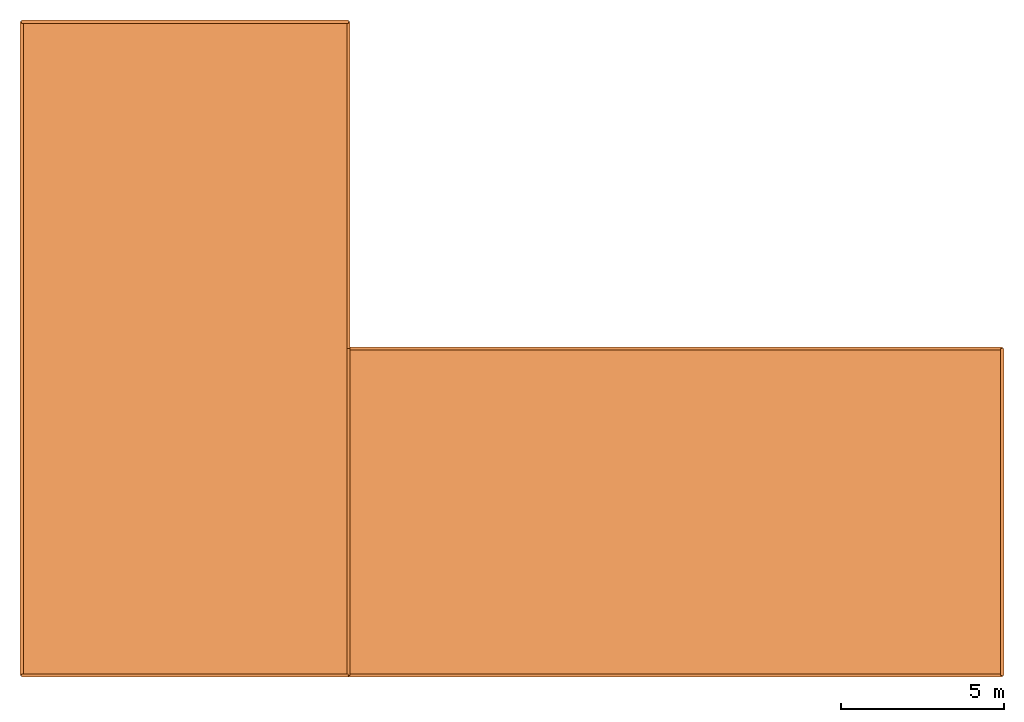
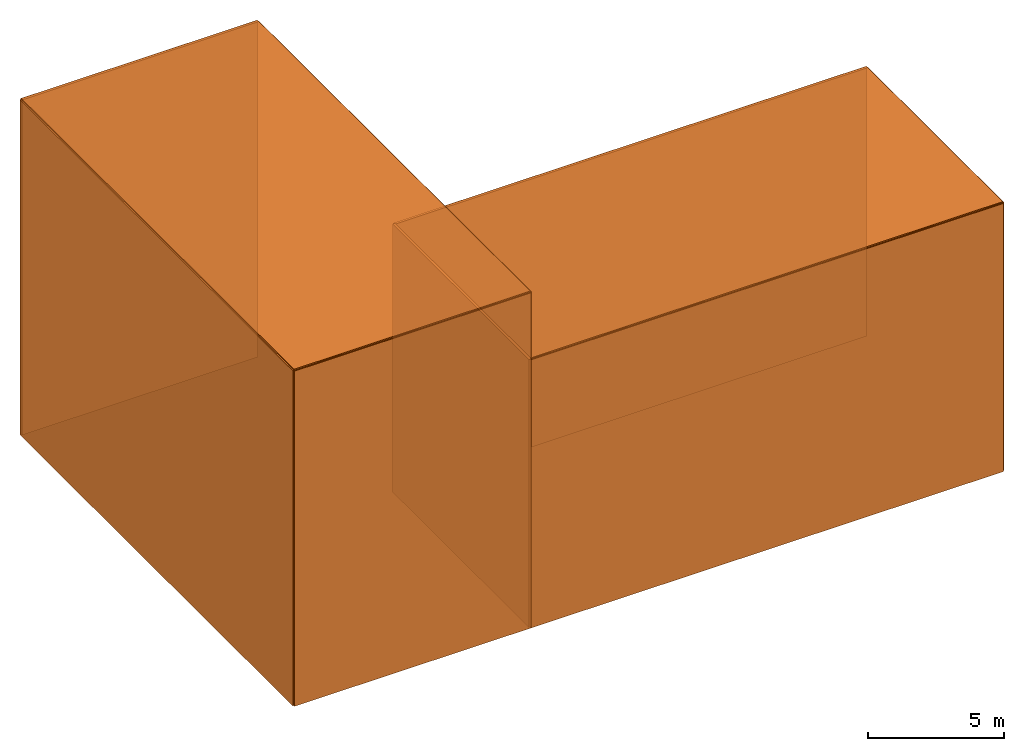
# Not in any storey: 11 proxies.
"""IFC4 building model written with IfcOpenShell, lengths in metres."""

import ifcopenshell
import ifcopenshell.guid

model = None  # the IFC model being written
_history = None  # IfcOwnerHistory: only IFC2X3 demands one
_inside = {}  # id of a spatial element -> (the spatial element, [elements in it])
_under = {}  # id of a project, library or spatial element -> (it, [spatial elements below it])
_declared = {}  # id of a project -> (the project, [libraries it declares])
_typed = {}  # id of a type object -> (the type object, [elements of that type])
_made_of = {}  # id of a material, layer set ... -> (it, [elements and type objects made of it])


def new_model(schema):
    """Start an empty IFC model of exactly this schema.

    Asked for "IFC4X3", IfcOpenShell would pick the latest addendum, in which some entities
    have other attributes; the version numbers below select the first issue.
    IFC2X3 requires an IfcOwnerHistory on every rooted entity: one is made here for all.
    """
    global model, _history
    if schema == "IFC4X3":
        model = ifcopenshell.file(schema_version=(4, 3, 0, 0))
    else:
        model = ifcopenshell.file(schema=schema)
    _inside.clear()
    _under.clear()
    _declared.clear()
    _typed.clear()
    _made_of.clear()
    _history = None
    if model.schema == "IFC2X3":
        org = make("IfcOrganization", Name="unknown")
        user = make(
            "IfcPersonAndOrganization",
            ThePerson=make("IfcPerson", FamilyName="unknown"),
            TheOrganization=org,
        )
        app = make(
            "IfcApplication",
            ApplicationDeveloper=org,
            Version="unknown",
            ApplicationFullName="unknown",
            ApplicationIdentifier="unknown",
        )
        _history = make(
            "IfcOwnerHistory",
            OwningUser=user,
            OwningApplication=app,
            ChangeAction="ADDED",
            CreationDate=0,
        )
    return model


def make(cls, **values):
    """One entity of the class cls with the attributes given. An attribute that is None is left unset."""
    return model.create_entity(
        cls, **{name: value for name, value in values.items() if value is not None}
    )


def rooted(cls, **values):
    """An entity with a GlobalId (a new one), such as an element, a storey or a relation."""
    return make(cls, GlobalId=ifcopenshell.guid.new(), OwnerHistory=_history, **values)


def si_unit(unit_type, name, prefix=None):
    """IfcSIUnit, for example si_unit("LENGTHUNIT", "METRE", prefix="MILLI")."""
    return make("IfcSIUnit", UnitType=unit_type, Prefix=prefix, Name=name)


def derived_unit(unit_type, elements):
    """IfcDerivedUnit: a product of units, each with its exponent."""
    return make(
        "IfcDerivedUnit",
        Elements=[
            make("IfcDerivedUnitElement", Unit=unit, Exponent=power)
            for unit, power in elements
        ],
        UnitType=unit_type,
    )


def assignment(units):
    """IfcUnitAssignment: the units of a project."""
    return None if units is None else make("IfcUnitAssignment", Units=units)


def point(xyz):
    """IfcCartesianPoint."""
    return None if xyz is None else make("IfcCartesianPoint", Coordinates=xyz)


def direction(xyz):
    """IfcDirection."""
    return None if xyz is None else make("IfcDirection", DirectionRatios=xyz)


def frame(location, z_axis=None, x_axis=None):
    """IfcAxis2Placement3D, a coordinate frame: its origin and axes. An axis left out is left unset."""
    return make(
        "IfcAxis2Placement3D",
        Location=point(location),
        Axis=direction(z_axis),
        RefDirection=direction(x_axis),
    )


def origin_with_axes():
    """The frame at (0, 0, 0) with the z axis (0, 0, 1) and the x axis (1, 0, 0) written out."""
    return frame((0.0, 0.0, 0.0), z_axis=(0.0, 0.0, 1.0), x_axis=(1.0, 0.0, 0.0))


def place(relative_to, where):
    """IfcLocalPlacement: puts the frame where relative to a parent placement (None: the world)."""
    return make(
        "IfcLocalPlacement", PlacementRelTo=relative_to, RelativePlacement=where
    )


def context(
    kind, dimensions, precision=None, world=None, true_north=None, identifier=None
):
    """IfcGeometricRepresentationContext, for example the 3D "Model" context."""
    return make(
        "IfcGeometricRepresentationContext",
        ContextIdentifier=identifier,
        ContextType=kind,
        CoordinateSpaceDimension=dimensions,
        Precision=precision,
        WorldCoordinateSystem=world,
        TrueNorth=true_north,
    )


def subcontext(parent, identifier, kind, view, scale=None):
    """IfcGeometricRepresentationSubContext, for example "Body" below "Model"."""
    return make(
        "IfcGeometricRepresentationSubContext",
        ContextIdentifier=identifier,
        ContextType=kind,
        ParentContext=parent,
        TargetScale=scale,
        TargetView=view,
    )


def project(units=None, contexts=None):
    """IfcProject with its units and contexts."""
    return rooted(
        "IfcProject",
        Name="project",
        RepresentationContexts=contexts,
        UnitsInContext=assignment(units),
    )


def spatial(cls, under=None, at=None, **own):
    """A site, building, storey or space (cls), placed at a placement, below another one or the project."""
    s = rooted(cls, ObjectPlacement=at, **own)
    if under is not None:
        _under.setdefault(under.id(), (under, []))[1].append(s)
    return s


def faces_of(points, faces, orient=None, outer=None):
    """IfcFace entities. A face is a list of loops; a loop is a list of indices into points, from 0.

    orient and outer hold one flag for each loop. By default every Orientation is true, the
    first loop of a face is its IfcFaceOuterBound and the others are IfcFaceBound.
    """
    made = []
    for i, loops in enumerate(faces):
        bounds = []
        for j, loop in enumerate(loops):
            is_outer = j == 0 if outer is None else outer[i][j]
            bounds.append(
                make(
                    "IfcFaceOuterBound" if is_outer else "IfcFaceBound",
                    Bound=make("IfcPolyLoop", Polygon=[points[k] for k in loop]),
                    Orientation=True if orient is None else orient[i][j],
                )
            )
        made.append(make("IfcFace", Bounds=bounds))
    return made


def faceted_brep(points, faces, orient=None, outer=None, voids=None):
    """IfcFacetedBrep: a solid bounded by flat faces; with voids (closed shells), ...WithVoids."""
    shared = [point(p) for p in points]
    hull = make("IfcClosedShell", CfsFaces=faces_of(shared, faces, orient, outer))
    if voids is None:
        return make("IfcFacetedBrep", Outer=hull)
    return make(
        "IfcFacetedBrepWithVoids",
        Outer=hull,
        Voids=[
            make(cls, CfsFaces=faces_of(shared, fs, o, b)) for cls, fs, o, b in voids
        ],
    )


def shape(context_of_items, identifier, shape_type, items):
    """IfcShapeRepresentation: the items that make up one representation, for example the "Body"."""
    return make(
        "IfcShapeRepresentation",
        ContextOfItems=context_of_items,
        RepresentationIdentifier=identifier,
        RepresentationType=shape_type,
        Items=items,
    )


def material(Name=None, Category=None):
    """IfcMaterial."""
    return make("IfcMaterial", Name=Name, Category=Category)


def made_of(thing, what):
    """Note that an element or type object is made of a material, layer set ...; save() writes the relation."""
    if what is not None:
        _made_of.setdefault(what.id(), (what, []))[1].append(thing)
    return thing


def element(
    cls,
    number,
    at=None,
    inside=None,
    cuts=None,
    type_object=None,
    material=None,
    context=None,
    identifier="Body",
    shape_type=None,
    held_by="IfcProductDefinitionShape",
    body=None,
    shapes=None,
    **own,
):
    """One element of the class cls, such as IfcWall. Its Tag is "e" and its number.

    at: its placement. inside: the storey or other place that contains it. cuts: it is an
    opening in that element (IfcRelVoidsElement). A single representation is given by context,
    identifier, shape_type and body (its items); several are given by shapes. held_by: the class
    of the entity that holds the representations. save() writes the other relations.
    """
    e = rooted(cls, Tag="e%d" % number, ObjectPlacement=at, **own)
    if body is not None:
        shapes = [shape(context, identifier, shape_type, body)]
    if shapes is not None:
        e.Representation = make(held_by, Representations=shapes)
    if inside is not None:
        _inside.setdefault(inside.id(), (inside, []))[1].append(e)
    if cuts is not None:
        rooted(
            "IfcRelVoidsElement", RelatingBuildingElement=cuts, RelatedOpeningElement=e
        )
    if type_object is not None:
        _typed.setdefault(type_object.id(), (type_object, []))[1].append(e)
    return made_of(e, material)


def aggregate(whole, parts):
    """IfcRelAggregates: a whole, such as a stair, and the parts it consists of."""
    return rooted("IfcRelAggregates", RelatingObject=whole, RelatedObjects=parts)


def save(model, path):
    """Write the relations noted so far, then the file.

    IfcRelAggregates (storeys below a building ...), IfcRelContainedInSpatialStructure (elements
    in a storey), IfcRelDefinesByType, IfcRelAssociatesMaterial and IfcRelDeclares: one each for
    every whole, place, type object, material and project.
    """
    for whole, parts in _under.values():
        aggregate(whole, parts)
    for where, things in _inside.values():
        rooted(
            "IfcRelContainedInSpatialStructure",
            RelatedElements=things,
            RelatingStructure=where,
        )
    for kind, things in _typed.values():
        rooted("IfcRelDefinesByType", RelatedObjects=things, RelatingType=kind)
    for what, things in _made_of.values():
        rooted("IfcRelAssociatesMaterial", RelatedObjects=things, RelatingMaterial=what)
    for by, libraries in _declared.values():
        rooted("IfcRelDeclares", RelatingContext=by, RelatedDefinitions=libraries)
    model.write(path)


model = new_model("IFC4")

# Units and contexts
model_context = context("Model", 3, precision=0.0005, world=origin_with_axes())
body_context = subcontext(model_context, "Body", "Model", "MODEL_VIEW")
ifc_project = project(units=[si_unit("AREAUNIT", "SQUARE_METRE"), si_unit("FORCEUNIT", "NEWTON"), si_unit("LENGTHUNIT", "METRE"), si_unit("MASSUNIT", "GRAM", prefix="KILO"), si_unit("PLANEANGLEUNIT", "RADIAN"), si_unit("THERMODYNAMICTEMPERATUREUNIT", "DEGREE_CELSIUS"), derived_unit("LINEARFORCEUNIT", [(si_unit("FORCEUNIT", "NEWTON"), 1), (si_unit("LENGTHUNIT", "METRE"), -1)]), derived_unit("LINEARMOMENTUNIT", [(si_unit("FORCEUNIT", "NEWTON"), 1), (si_unit("LENGTHUNIT", "METRE"), 1), (si_unit("LENGTHUNIT", "METRE"), -1)]), derived_unit("LINEARSTIFFNESSUNIT", [(si_unit("FORCEUNIT", "NEWTON"), 1), (si_unit("LENGTHUNIT", "METRE"), -1)]), derived_unit("MASSDENSITYUNIT", [(si_unit("MASSUNIT", "GRAM", prefix="KILO"), 1), (si_unit("LENGTHUNIT", "METRE"), -3)]), derived_unit("MODULUSOFELASTICITYUNIT", [(si_unit("FORCEUNIT", "NEWTON"), 1), (si_unit("LENGTHUNIT", "METRE"), -2)]), derived_unit("MODULUSOFSUBGRADEREACTIONUNIT", [(si_unit("FORCEUNIT", "NEWTON"), 1), (si_unit("LENGTHUNIT", "METRE"), 1), (si_unit("LENGTHUNIT", "METRE"), -1), (si_unit("PLANEANGLEUNIT", "RADIAN"), -1)]), derived_unit("MOMENTOFINERTIAUNIT", [(si_unit("LENGTHUNIT", "METRE"), 4)]), derived_unit("PLANARFORCEUNIT", [(si_unit("FORCEUNIT", "NEWTON"), 1), (si_unit("LENGTHUNIT", "METRE"), -2)]), derived_unit("ROTATIONALSTIFFNESSUNIT", [(si_unit("FORCEUNIT", "NEWTON"), 1), (si_unit("LENGTHUNIT", "METRE"), 1), (si_unit("PLANEANGLEUNIT", "RADIAN"), -1)]), derived_unit("SHEARMODULUSUNIT", [(si_unit("FORCEUNIT", "NEWTON"), 1), (si_unit("LENGTHUNIT", "METRE"), -2)]), derived_unit("THERMALEXPANSIONCOEFFICIENTUNIT", [(si_unit("THERMODYNAMICTEMPERATUREUNIT", "DEGREE_CELSIUS"), -1)]), derived_unit("TORQUEUNIT", [(si_unit("FORCEUNIT", "NEWTON"), 1), (si_unit("LENGTHUNIT", "METRE"), 1)])], contexts=[model_context])

# Building
placement = place(None, origin_with_axes())
building = spatial("IfcBuilding", under=ifc_project, at=placement, CompositionType="ELEMENT")

# Proxies
ifc_material = material()
element("IfcBuildingElementProxy", 1, at=placement, inside=building, material=ifc_material, Name="Surface 11", context=body_context, shape_type="Brep", body=[
    faceted_brep([(0.0, 0.0, 15.0500001907349), (10.0, 0.0, 15.0500001907349), (10.0, 10.0, 15.0500001907349), (0.0, 0.0, 15.0500001907349), (10.0, 10.0, 15.0500001907349), (10.0, 20.0, 15.0500001907349), (0.0, 0.0, 15.0500001907349), (10.0, 20.0, 15.0500001907349), (0.0, 20.0, 15.0500001907349), (0.0, 20.0, 14.9499998092651), (0.0, 0.0, 15.0500001907349), (0.0, 20.0, 15.0500001907349), (0.0, 0.0, 14.9499998092651), (0.0, 0.0, 15.0500001907349), (0.0, 20.0, 14.9499998092651), (0.0, 0.0, 14.9499998092651), (0.0, 20.0, 14.9499998092651), (10.0, 20.0, 14.9499998092651), (0.0, 0.0, 14.9499998092651), (10.0, 20.0, 14.9499998092651), (10.0, 10.0, 14.9499998092651), (0.0, 0.0, 14.9499998092651), (10.0, 10.0, 14.9499998092651), (10.0, 0.0, 14.9499998092651), (10.0, 20.0, 14.9499998092651), (0.0, 20.0, 15.0500001907349), (10.0, 20.0, 15.0500001907349), (0.0, 20.0, 14.9499998092651), (0.0, 20.0, 15.0500001907349), (10.0, 20.0, 14.9499998092651), (10.0, 10.0, 14.9499998092651), (10.0, 20.0, 15.0500001907349), (10.0, 10.0, 15.0500001907349), (10.0, 20.0, 14.9499998092651), (10.0, 20.0, 15.0500001907349), (10.0, 10.0, 14.9499998092651), (10.0, 0.0, 14.9499998092651), (10.0, 10.0, 15.0500001907349), (10.0, 0.0, 15.0500001907349), (10.0, 10.0, 14.9499998092651), (10.0, 10.0, 15.0500001907349), (10.0, 0.0, 14.9499998092651), (0.0, 0.0, 14.9499998092651), (10.0, 0.0, 15.0500001907349), (0.0, 0.0, 15.0500001907349), (10.0, 0.0, 14.9499998092651), (10.0, 0.0, 15.0500001907349), (0.0, 0.0, 14.9499998092651)], [[[0, 1, 2]], [[3, 4, 5]], [[6, 7, 8]], [[9, 10, 11]], [[12, 13, 14]], [[15, 16, 17]], [[18, 19, 20]], [[21, 22, 23]], [[24, 25, 26]], [[27, 28, 29]], [[30, 31, 32]], [[33, 34, 35]], [[36, 37, 38]], [[39, 40, 41]], [[42, 43, 44]], [[45, 46, 47]]]),
])
element("IfcBuildingElementProxy", 2, at=placement, inside=building, material=ifc_material, Name="Surface 4", context=body_context, shape_type="Brep", body=[
    faceted_brep([(10.0, -0.0500000007450581, 0.0), (30.0, -0.0500000007450581, 0.0), (30.0, -0.0500000007450581, 12.0), (10.0, -0.0500000007450581, 0.0), (30.0, -0.0500000007450581, 12.0), (10.0, -0.0500000007450581, 12.0), (10.0, -0.0500000007450581, 0.0), (30.0, 0.0500000007450581, 0.0), (30.0, -0.0500000007450581, 0.0), (10.0, -0.0500000007450581, 0.0), (10.0, 0.0500000007450581, 0.0), (30.0, 0.0500000007450581, 0.0), (10.0, 0.0500000007450581, 0.0), (10.0, 0.0500000007450581, 12.0), (30.0, 0.0500000007450581, 12.0), (10.0, 0.0500000007450581, 0.0), (30.0, 0.0500000007450581, 12.0), (30.0, 0.0500000007450581, 0.0), (30.0, -0.0500000007450581, 0.0), (30.0, 0.0500000007450581, 12.0), (30.0, -0.0500000007450581, 12.0), (30.0, -0.0500000007450581, 0.0), (30.0, 0.0500000007450581, 0.0), (30.0, 0.0500000007450581, 12.0), (30.0, -0.0500000007450581, 12.0), (10.0, 0.0500000007450581, 12.0), (10.0, -0.0500000007450581, 12.0), (30.0, -0.0500000007450581, 12.0), (30.0, 0.0500000007450581, 12.0), (10.0, 0.0500000007450581, 12.0), (10.0, -0.0500000007450581, 12.0), (10.0, 0.0500000007450581, 0.0), (10.0, -0.0500000007450581, 0.0), (10.0, -0.0500000007450581, 12.0), (10.0, 0.0500000007450581, 12.0), (10.0, 0.0500000007450581, 0.0)], [[[0, 1, 2]], [[3, 4, 5]], [[6, 7, 8]], [[9, 10, 11]], [[12, 13, 14]], [[15, 16, 17]], [[18, 19, 20]], [[21, 22, 23]], [[24, 25, 26]], [[27, 28, 29]], [[30, 31, 32]], [[33, 34, 35]]]),
])
element("IfcBuildingElementProxy", 3, at=placement, inside=building, material=ifc_material, Name="Surface 7", context=body_context, shape_type="Brep", body=[
    faceted_brep([(30.0499992370605, 0.0, 0.0), (30.0499992370605, 10.0, 0.0), (30.0499992370605, 10.0, 12.0), (30.0499992370605, 0.0, 0.0), (30.0499992370605, 10.0, 12.0), (30.0499992370605, 0.0, 12.0), (30.0499992370605, 0.0, 0.0), (29.9500007629395, 10.0, 0.0), (30.0499992370605, 10.0, 0.0), (30.0499992370605, 0.0, 0.0), (29.9500007629395, 0.0, 0.0), (29.9500007629395, 10.0, 0.0), (29.9500007629395, 0.0, 0.0), (29.9500007629395, 0.0, 12.0), (29.9500007629395, 10.0, 12.0), (29.9500007629395, 0.0, 0.0), (29.9500007629395, 10.0, 12.0), (29.9500007629395, 10.0, 0.0), (30.0499992370605, 10.0, 0.0), (29.9500007629395, 10.0, 12.0), (30.0499992370605, 10.0, 12.0), (30.0499992370605, 10.0, 0.0), (29.9500007629395, 10.0, 0.0), (29.9500007629395, 10.0, 12.0), (30.0499992370605, 10.0, 12.0), (29.9500007629395, 0.0, 12.0), (30.0499992370605, 0.0, 12.0), (30.0499992370605, 10.0, 12.0), (29.9500007629395, 10.0, 12.0), (29.9500007629395, 0.0, 12.0), (30.0499992370605, 0.0, 12.0), (29.9500007629395, 0.0, 0.0), (30.0499992370605, 0.0, 0.0), (30.0499992370605, 0.0, 12.0), (29.9500007629395, 0.0, 12.0), (29.9500007629395, 0.0, 0.0)], [[[0, 1, 2]], [[3, 4, 5]], [[6, 7, 8]], [[9, 10, 11]], [[12, 13, 14]], [[15, 16, 17]], [[18, 19, 20]], [[21, 22, 23]], [[24, 25, 26]], [[27, 28, 29]], [[30, 31, 32]], [[33, 34, 35]]]),
])
element("IfcBuildingElementProxy", 4, at=placement, inside=building, material=ifc_material, Name="Surface 6", context=body_context, shape_type="Brep", body=[
    faceted_brep([(30.0, 10.0500001907349, 0.0), (10.0, 10.0500001907349, 0.0), (10.0, 10.0500001907349, 12.0), (30.0, 10.0500001907349, 0.0), (10.0, 10.0500001907349, 12.0), (30.0, 10.0500001907349, 12.0), (30.0, 10.0500001907349, 0.0), (10.0, 9.94999980926514, 0.0), (10.0, 10.0500001907349, 0.0), (30.0, 10.0500001907349, 0.0), (30.0, 9.94999980926514, 0.0), (10.0, 9.94999980926514, 0.0), (30.0, 9.94999980926514, 0.0), (30.0, 9.94999980926514, 12.0), (10.0, 9.94999980926514, 12.0), (30.0, 9.94999980926514, 0.0), (10.0, 9.94999980926514, 12.0), (10.0, 9.94999980926514, 0.0), (10.0, 10.0500001907349, 0.0), (10.0, 9.94999980926514, 12.0), (10.0, 10.0500001907349, 12.0), (10.0, 10.0500001907349, 0.0), (10.0, 9.94999980926514, 0.0), (10.0, 9.94999980926514, 12.0), (10.0, 10.0500001907349, 12.0), (30.0, 9.94999980926514, 12.0), (30.0, 10.0500001907349, 12.0), (10.0, 10.0500001907349, 12.0), (10.0, 9.94999980926514, 12.0), (30.0, 9.94999980926514, 12.0), (30.0, 10.0500001907349, 12.0), (30.0, 9.94999980926514, 0.0), (30.0, 10.0500001907349, 0.0), (30.0, 10.0500001907349, 12.0), (30.0, 9.94999980926514, 12.0), (30.0, 9.94999980926514, 0.0)], [[[0, 1, 2]], [[3, 4, 5]], [[6, 7, 8]], [[9, 10, 11]], [[12, 13, 14]], [[15, 16, 17]], [[18, 19, 20]], [[21, 22, 23]], [[24, 25, 26]], [[27, 28, 29]], [[30, 31, 32]], [[33, 34, 35]]]),
])
element("IfcBuildingElementProxy", 5, at=placement, inside=building, material=ifc_material, Name="Surface 8", context=body_context, shape_type="Brep", body=[
    faceted_brep([(10.0500001907349, 0.0, 0.0), (10.0500001907349, 10.0, 0.0), (10.0500001907349, 10.0, 12.0), (10.0500001907349, 0.0, 0.0), (10.0500001907349, 10.0, 12.0), (10.0500001907349, 0.0, 12.0), (10.0500001907349, 0.0, 0.0), (9.94999980926514, 10.0, 0.0), (10.0500001907349, 10.0, 0.0), (10.0500001907349, 0.0, 0.0), (9.94999980926514, 0.0, 0.0), (9.94999980926514, 10.0, 0.0), (9.94999980926514, 0.0, 0.0), (9.94999980926514, 0.0, 12.0), (9.94999980926514, 10.0, 12.0), (9.94999980926514, 0.0, 0.0), (9.94999980926514, 10.0, 12.0), (9.94999980926514, 10.0, 0.0), (10.0500001907349, 10.0, 0.0), (9.94999980926514, 10.0, 12.0), (10.0500001907349, 10.0, 12.0), (10.0500001907349, 10.0, 0.0), (9.94999980926514, 10.0, 0.0), (9.94999980926514, 10.0, 12.0), (10.0500001907349, 10.0, 12.0), (9.94999980926514, 0.0, 12.0), (10.0500001907349, 0.0, 12.0), (10.0500001907349, 10.0, 12.0), (9.94999980926514, 10.0, 12.0), (9.94999980926514, 0.0, 12.0), (10.0500001907349, 0.0, 12.0), (9.94999980926514, 0.0, 0.0), (10.0500001907349, 0.0, 0.0), (10.0500001907349, 0.0, 12.0), (9.94999980926514, 0.0, 12.0), (9.94999980926514, 0.0, 0.0)], [[[0, 1, 2]], [[3, 4, 5]], [[6, 7, 8]], [[9, 10, 11]], [[12, 13, 14]], [[15, 16, 17]], [[18, 19, 20]], [[21, 22, 23]], [[24, 25, 26]], [[27, 28, 29]], [[30, 31, 32]], [[33, 34, 35]]]),
])
element("IfcBuildingElementProxy", 6, at=placement, inside=building, material=ifc_material, Name="Surface 9", context=body_context, shape_type="Brep", body=[
    faceted_brep([(9.94999980926514, 0.0, 15.0), (9.94999980926514, 10.0, 15.0), (9.94999980926514, 10.0, 12.0), (9.94999980926514, 0.0, 15.0), (9.94999980926514, 10.0, 12.0), (9.94999980926514, 0.0, 12.0), (9.94999980926514, 0.0, 15.0), (10.0500001907349, 10.0, 15.0), (9.94999980926514, 10.0, 15.0), (9.94999980926514, 0.0, 15.0), (10.0500001907349, 0.0, 15.0), (10.0500001907349, 10.0, 15.0), (10.0500001907349, 0.0, 15.0), (10.0500001907349, 0.0, 12.0), (10.0500001907349, 10.0, 12.0), (10.0500001907349, 0.0, 15.0), (10.0500001907349, 10.0, 12.0), (10.0500001907349, 10.0, 15.0), (9.94999980926514, 10.0, 15.0), (10.0500001907349, 10.0, 12.0), (9.94999980926514, 10.0, 12.0), (9.94999980926514, 10.0, 15.0), (10.0500001907349, 10.0, 15.0), (10.0500001907349, 10.0, 12.0), (9.94999980926514, 10.0, 12.0), (10.0500001907349, 0.0, 12.0), (9.94999980926514, 0.0, 12.0), (9.94999980926514, 10.0, 12.0), (10.0500001907349, 10.0, 12.0), (10.0500001907349, 0.0, 12.0), (9.94999980926514, 0.0, 12.0), (10.0500001907349, 0.0, 15.0), (9.94999980926514, 0.0, 15.0), (9.94999980926514, 0.0, 12.0), (10.0500001907349, 0.0, 12.0), (10.0500001907349, 0.0, 15.0)], [[[0, 1, 2]], [[3, 4, 5]], [[6, 7, 8]], [[9, 10, 11]], [[12, 13, 14]], [[15, 16, 17]], [[18, 19, 20]], [[21, 22, 23]], [[24, 25, 26]], [[27, 28, 29]], [[30, 31, 32]], [[33, 34, 35]]]),
])
element("IfcBuildingElementProxy", 7, at=placement, inside=building, material=ifc_material, Name="Surface 10", context=body_context, shape_type="Brep", body=[
    faceted_brep([(10.0, 0.0, 12.0500001907349), (30.0, 0.0, 12.0500001907349), (30.0, 10.0, 12.0500001907349), (10.0, 0.0, 12.0500001907349), (30.0, 10.0, 12.0500001907349), (10.0, 10.0, 12.0500001907349), (10.0, 0.0, 12.0500001907349), (30.0, 0.0, 11.9499998092651), (30.0, 0.0, 12.0500001907349), (10.0, 0.0, 12.0500001907349), (10.0, 0.0, 11.9499998092651), (30.0, 0.0, 11.9499998092651), (10.0, 0.0, 11.9499998092651), (10.0, 10.0, 11.9499998092651), (30.0, 10.0, 11.9499998092651), (10.0, 0.0, 11.9499998092651), (30.0, 10.0, 11.9499998092651), (30.0, 0.0, 11.9499998092651), (30.0, 0.0, 12.0500001907349), (30.0, 10.0, 11.9499998092651), (30.0, 10.0, 12.0500001907349), (30.0, 0.0, 12.0500001907349), (30.0, 0.0, 11.9499998092651), (30.0, 10.0, 11.9499998092651), (30.0, 10.0, 12.0500001907349), (10.0, 10.0, 11.9499998092651), (10.0, 10.0, 12.0500001907349), (30.0, 10.0, 12.0500001907349), (30.0, 10.0, 11.9499998092651), (10.0, 10.0, 11.9499998092651), (10.0, 10.0, 12.0500001907349), (10.0, 0.0, 11.9499998092651), (10.0, 0.0, 12.0500001907349), (10.0, 10.0, 12.0500001907349), (10.0, 10.0, 11.9499998092651), (10.0, 0.0, 11.9499998092651)], [[[0, 1, 2]], [[3, 4, 5]], [[6, 7, 8]], [[9, 10, 11]], [[12, 13, 14]], [[15, 16, 17]], [[18, 19, 20]], [[21, 22, 23]], [[24, 25, 26]], [[27, 28, 29]], [[30, 31, 32]], [[33, 34, 35]]]),
])
element("IfcBuildingElementProxy", 8, at=placement, inside=building, material=ifc_material, Name="Surface 5", context=body_context, shape_type="Brep", body=[
    faceted_brep([(0.0, -0.0500000007450581, 0.0), (10.0, -0.0500000007450581, 0.0), (10.0, -0.0500000007450581, 12.0), (0.0, -0.0500000007450581, 0.0), (10.0, -0.0500000007450581, 12.0), (10.0, -0.0500000007450581, 15.0), (0.0, -0.0500000007450581, 0.0), (10.0, -0.0500000007450581, 15.0), (0.0, -0.0500000007450581, 15.0), (0.0, -0.0500000007450581, 0.0), (10.0, 0.0500000007450581, 0.0), (10.0, -0.0500000007450581, 0.0), (0.0, -0.0500000007450581, 0.0), (0.0, 0.0500000007450581, 0.0), (10.0, 0.0500000007450581, 0.0), (0.0, 0.0500000007450581, 0.0), (0.0, 0.0500000007450581, 15.0), (10.0, 0.0500000007450581, 15.0), (0.0, 0.0500000007450581, 0.0), (10.0, 0.0500000007450581, 15.0), (10.0, 0.0500000007450581, 12.0), (0.0, 0.0500000007450581, 0.0), (10.0, 0.0500000007450581, 12.0), (10.0, 0.0500000007450581, 0.0), (10.0, -0.0500000007450581, 0.0), (10.0, 0.0500000007450581, 12.0), (10.0, -0.0500000007450581, 12.0), (10.0, -0.0500000007450581, 0.0), (10.0, 0.0500000007450581, 0.0), (10.0, 0.0500000007450581, 12.0), (10.0, -0.0500000007450581, 12.0), (10.0, 0.0500000007450581, 15.0), (10.0, -0.0500000007450581, 15.0), (10.0, -0.0500000007450581, 12.0), (10.0, 0.0500000007450581, 12.0), (10.0, 0.0500000007450581, 15.0), (10.0, -0.0500000007450581, 15.0), (0.0, 0.0500000007450581, 15.0), (0.0, -0.0500000007450581, 15.0), (10.0, -0.0500000007450581, 15.0), (10.0, 0.0500000007450581, 15.0), (0.0, 0.0500000007450581, 15.0), (0.0, -0.0500000007450581, 15.0), (0.0, 0.0500000007450581, 0.0), (0.0, -0.0500000007450581, 0.0), (0.0, -0.0500000007450581, 15.0), (0.0, 0.0500000007450581, 15.0), (0.0, 0.0500000007450581, 0.0)], [[[0, 1, 2]], [[3, 4, 5]], [[6, 7, 8]], [[9, 10, 11]], [[12, 13, 14]], [[15, 16, 17]], [[18, 19, 20]], [[21, 22, 23]], [[24, 25, 26]], [[27, 28, 29]], [[30, 31, 32]], [[33, 34, 35]], [[36, 37, 38]], [[39, 40, 41]], [[42, 43, 44]], [[45, 46, 47]]]),
])
element("IfcBuildingElementProxy", 9, at=placement, inside=building, material=ifc_material, Name="Surface 1", context=body_context, shape_type="Brep", body=[
    faceted_brep([(-0.0500000007450581, 20.0, 0.0), (-0.0500000007450581, 0.0, 0.0), (-0.0500000007450581, 0.0, 15.0), (-0.0500000007450581, 20.0, 0.0), (-0.0500000007450581, 0.0, 15.0), (-0.0500000007450581, 20.0, 15.0), (-0.0500000007450581, 20.0, 0.0), (0.0500000007450581, 0.0, 0.0), (-0.0500000007450581, 0.0, 0.0), (-0.0500000007450581, 20.0, 0.0), (0.0500000007450581, 20.0, 0.0), (0.0500000007450581, 0.0, 0.0), (0.0500000007450581, 20.0, 0.0), (0.0500000007450581, 20.0, 15.0), (0.0500000007450581, 0.0, 15.0), (0.0500000007450581, 20.0, 0.0), (0.0500000007450581, 0.0, 15.0), (0.0500000007450581, 0.0, 0.0), (-0.0500000007450581, 0.0, 0.0), (0.0500000007450581, 0.0, 15.0), (-0.0500000007450581, 0.0, 15.0), (-0.0500000007450581, 0.0, 0.0), (0.0500000007450581, 0.0, 0.0), (0.0500000007450581, 0.0, 15.0), (-0.0500000007450581, 0.0, 15.0), (0.0500000007450581, 20.0, 15.0), (-0.0500000007450581, 20.0, 15.0), (-0.0500000007450581, 0.0, 15.0), (0.0500000007450581, 0.0, 15.0), (0.0500000007450581, 20.0, 15.0), (-0.0500000007450581, 20.0, 15.0), (0.0500000007450581, 20.0, 0.0), (-0.0500000007450581, 20.0, 0.0), (-0.0500000007450581, 20.0, 15.0), (0.0500000007450581, 20.0, 15.0), (0.0500000007450581, 20.0, 0.0)], [[[0, 1, 2]], [[3, 4, 5]], [[6, 7, 8]], [[9, 10, 11]], [[12, 13, 14]], [[15, 16, 17]], [[18, 19, 20]], [[21, 22, 23]], [[24, 25, 26]], [[27, 28, 29]], [[30, 31, 32]], [[33, 34, 35]]]),
])
element("IfcBuildingElementProxy", 10, at=placement, inside=building, material=ifc_material, Name="Surface 2", context=body_context, shape_type="Brep", body=[
    faceted_brep([(10.0, 20.0499992370605, 0.0), (0.0, 20.0499992370605, 0.0), (0.0, 20.0499992370605, 15.0), (10.0, 20.0499992370605, 0.0), (0.0, 20.0499992370605, 15.0), (10.0, 20.0499992370605, 15.0), (10.0, 20.0499992370605, 0.0), (0.0, 19.9500007629395, 0.0), (0.0, 20.0499992370605, 0.0), (10.0, 20.0499992370605, 0.0), (10.0, 19.9500007629395, 0.0), (0.0, 19.9500007629395, 0.0), (10.0, 19.9500007629395, 0.0), (10.0, 19.9500007629395, 15.0), (0.0, 19.9500007629395, 15.0), (10.0, 19.9500007629395, 0.0), (0.0, 19.9500007629395, 15.0), (0.0, 19.9500007629395, 0.0), (0.0, 20.0499992370605, 0.0), (0.0, 19.9500007629395, 15.0), (0.0, 20.0499992370605, 15.0), (0.0, 20.0499992370605, 0.0), (0.0, 19.9500007629395, 0.0), (0.0, 19.9500007629395, 15.0), (0.0, 20.0499992370605, 15.0), (10.0, 19.9500007629395, 15.0), (10.0, 20.0499992370605, 15.0), (0.0, 20.0499992370605, 15.0), (0.0, 19.9500007629395, 15.0), (10.0, 19.9500007629395, 15.0), (10.0, 20.0499992370605, 15.0), (10.0, 19.9500007629395, 0.0), (10.0, 20.0499992370605, 0.0), (10.0, 20.0499992370605, 15.0), (10.0, 19.9500007629395, 15.0), (10.0, 19.9500007629395, 0.0)], [[[0, 1, 2]], [[3, 4, 5]], [[6, 7, 8]], [[9, 10, 11]], [[12, 13, 14]], [[15, 16, 17]], [[18, 19, 20]], [[21, 22, 23]], [[24, 25, 26]], [[27, 28, 29]], [[30, 31, 32]], [[33, 34, 35]]]),
])
element("IfcBuildingElementProxy", 11, at=placement, inside=building, material=ifc_material, Name="Surface 3", context=body_context, shape_type="Brep", body=[
    faceted_brep([(10.0500001907349, 10.0, 0.0), (10.0500001907349, 20.0, 0.0), (10.0500001907349, 20.0, 15.0), (10.0500001907349, 10.0, 0.0), (10.0500001907349, 20.0, 15.0), (10.0500001907349, 10.0, 15.0), (10.0500001907349, 10.0, 0.0), (10.0500001907349, 10.0, 15.0), (10.0500001907349, 10.0, 12.0), (10.0500001907349, 10.0, 0.0), (9.94999980926514, 20.0, 0.0), (10.0500001907349, 20.0, 0.0), (10.0500001907349, 10.0, 0.0), (9.94999980926514, 10.0, 0.0), (9.94999980926514, 20.0, 0.0), (9.94999980926514, 10.0, 12.0), (9.94999980926514, 10.0, 0.0), (9.94999980926514, 10.0, 12.0), (9.94999980926514, 10.0, 15.0), (9.94999980926514, 10.0, 0.0), (9.94999980926514, 10.0, 12.0), (9.94999980926514, 10.0, 15.0), (9.94999980926514, 20.0, 15.0), (9.94999980926514, 10.0, 0.0), (9.94999980926514, 20.0, 15.0), (9.94999980926514, 20.0, 0.0), (10.0500001907349, 20.0, 0.0), (9.94999980926514, 20.0, 15.0), (10.0500001907349, 20.0, 15.0), (10.0500001907349, 20.0, 0.0), (9.94999980926514, 20.0, 0.0), (9.94999980926514, 20.0, 15.0), (10.0500001907349, 20.0, 15.0), (9.94999980926514, 10.0, 15.0), (10.0500001907349, 10.0, 15.0), (10.0500001907349, 20.0, 15.0), (9.94999980926514, 20.0, 15.0), (9.94999980926514, 10.0, 15.0), (10.0500001907349, 10.0, 15.0), (9.94999980926514, 10.0, 12.0), (10.0500001907349, 10.0, 12.0), (10.0500001907349, 10.0, 15.0), (9.94999980926514, 10.0, 15.0), (9.94999980926514, 10.0, 12.0), (10.0500001907349, 10.0, 12.0), (9.94999980926514, 10.0, 0.0), (10.0500001907349, 10.0, 0.0), (10.0500001907349, 10.0, 12.0), (9.94999980926514, 10.0, 12.0), (9.94999980926514, 10.0, 0.0)], [[[0, 1, 2]], [[3, 4, 5]], [[6, 7, 8]], [[9, 10, 11]], [[12, 13, 14]], [[15, 16, 17, 18]], [[19, 20, 21, 22]], [[23, 24, 25]], [[26, 27, 28]], [[29, 30, 31]], [[32, 33, 34]], [[35, 36, 37]], [[38, 39, 40]], [[41, 42, 43]], [[44, 45, 46]], [[47, 48, 49]]]),
])

save(model, "model.ifc")
